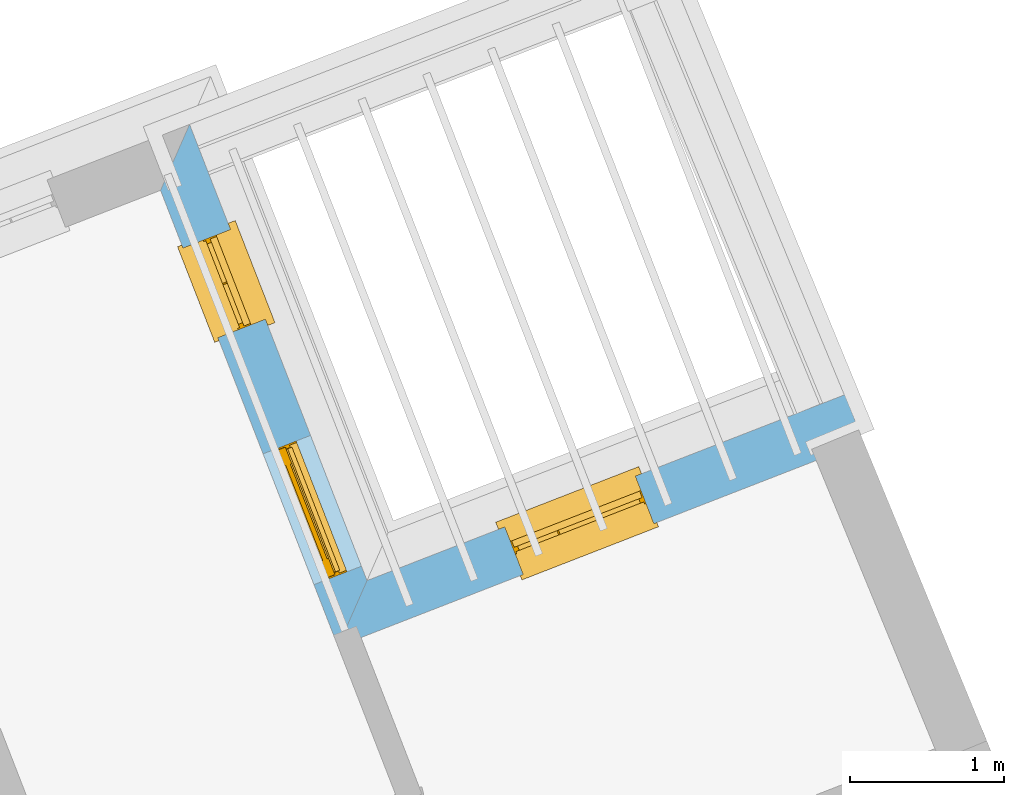
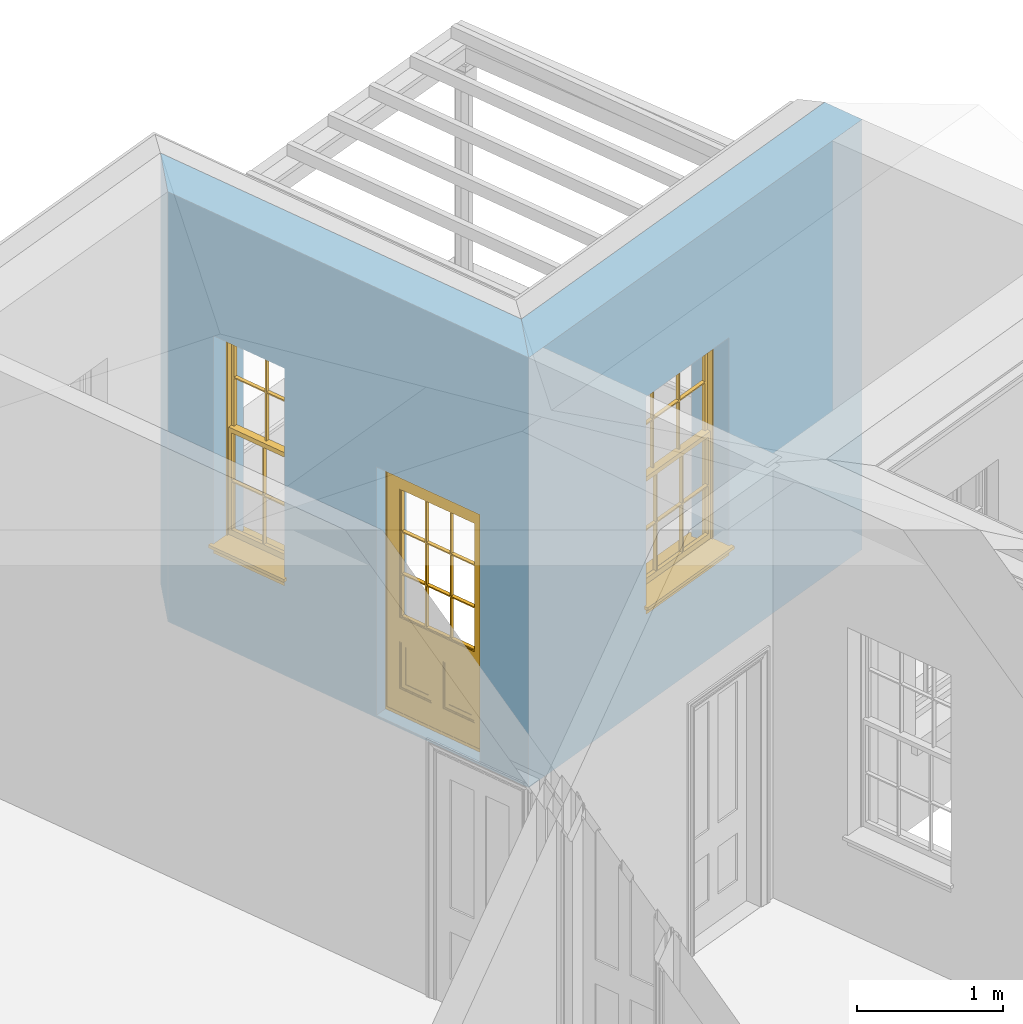
# One storey, part 9 of 11: 2 windows, 1 door, 3 openings, plus 2 elements that do not belong to this part.
"""IFC2X3 building model written with IfcOpenShell, lengths in metres."""

from ifc_helpers import new_model, si_unit, frame, origin, place, context, subcontext, project, spatial, polyline, outline, extrude, faceted_brep, material, layer, layer_set, layer_usage, element, fill, save


model = new_model("IFC2X3")

# Units and contexts
model_context = context("Model", 3, world=origin())
body_context = subcontext(model_context, "Body", "Model", "MODEL_VIEW")
ifc_project = project(units=[si_unit("PLANEANGLEUNIT", "RADIAN"), si_unit("MASSUNIT", "GRAM", prefix="KILO"), si_unit("FORCEUNIT", "NEWTON", prefix="KILO"), si_unit("LENGTHUNIT", "METRE")], contexts=[model_context])

# Site, building, storey
site_placement = place(None, origin())
site = spatial("IfcSite", under=ifc_project, at=site_placement, CompositionType="ELEMENT")
building_placement = place(None, origin())
building = spatial("IfcBuilding", under=site, at=building_placement, Name="Building plot-3", CompositionType="ELEMENT")
storey_placement = place(None, frame((0.0, 0.0, 5.45)))
storey = spatial("IfcBuildingStorey", under=building, at=storey_placement, Name="Floor 1", CompositionType="ELEMENT", Elevation=5.45)

# Wall, opening, window
ifc_material = material(Name="Masonry")
ifc_layer = layer(ifc_material, 0.33, ventilated=False)
ifc_layer_set = layer_set([ifc_layer], Name="My Wall")
ifc_layer_usage = layer_usage(ifc_layer_set, "AXIS2", "NEGATIVE", 0.08)
wall_1_placement = place(storey_placement, origin())
wall_1 = element("IfcWallStandardCase", 1, at=wall_1_placement, inside=storey, material=ifc_layer_usage, Name="exterior", context=body_context, shape_type="SweptSolid", body=[
    extrude(outline(polyline([(43.840490390188, 51.5411519545112), (43.7208486319546, 51.8487000803173), (40.6222717045672, 50.6432978667857), (40.4343653369945, 50.2161079827462), (43.840490390188, 51.5411519545112)])), origin(), (0.0, 0.0, 1.0), 3.6),
])
opening_1_placement = place(storey_placement, frame((0.0, 0.0, 0.75)))
opening_1 = element("IfcOpeningElement", 2, at=opening_1_placement, cuts=wall_1, Name="Opening", ObjectType="Opening", context=body_context, shape_type="SweptSolid", body=[
    extrude(outline(polyline([(42.3626127918676, 51.3203218839692), (41.514525535857, 50.990400671871), (41.6341672940904, 50.682852546065), (42.4822545501011, 51.0127737581632), (42.3626127918676, 51.3203218839692)])), origin(), (0.0, 0.0, 1.0), 1.82),
])
window_1_placement = place(storey_placement, frame((42.453250487499, 51.0873308795707, 0.75), z_axis=(0.0, 0.0, 1.0), x_axis=(-0.848087256010643, -0.329921212098199, 0.0)))
window_1 = element("IfcWindow", 3, at=window_1_placement, inside=storey, Name="toilet outside window", OverallHeight=1.82, OverallWidth=0.91, context=body_context, shape_type="Brep", held_by="IfcProductRepresentation", body=[
    faceted_brep([(0.033125, -0.105, 0.975209), (0.01, -0.105, 0.975209), (0.033125, -0.105, 1.376042), (0.876875, -0.105, 0.975209), (0.876875, -0.105, 1.376042), (0.9, -0.105, 0.975209), (0.876875, -0.105, 1.386042), (0.876875, -0.105, 1.786875), (0.9, -0.105, 1.81), (0.033125, -0.105, 1.786875), (0.033125, -0.105, 1.386042), (0.01, -0.105, 1.81), (0.876875, -0.135, 1.376042), (0.876875, -0.135, 0.975209), (0.9, -0.135, 0.937083), (0.033125, -0.135, 1.786875), (0.01, -0.135, 1.81), (0.033125, -0.135, 1.386042), (0.01, -0.135, 0.937083), (0.033125, -0.135, 0.975209), (0.033125, -0.135, 1.376042), (0.876875, -0.135, 1.786875), (0.876875, -0.135, 1.386042), (0.9, -0.135, 1.81), (0.033125, -0.105, 0.937083), (0.01, -0.105, 0.937083), (0.033125, -0.105, 0.53625), (0.876875, -0.105, 0.937083), (0.876875, -0.105, 0.53625), (0.9, -0.105, 0.937083), (0.876875, -0.105, 0.52625), (0.876875, -0.105, 0.125417), (0.9, -0.105, 0.077167), (0.033125, -0.105, 0.125417), (0.033125, -0.105, 0.52625), (0.01, -0.105, 0.077167), (-0.0425, -0.25, 0.01), (-0.0425, -0.3, 0.001667), (0.0, -0.25, 0.01), (0.9525, -0.25, 0.01), (0.91, -0.25, 0.01), (0.9525, -0.3, 0.001667), (-0.02, 0.08, 0.077167), (0.0, 0.08, 0.077167), (-0.02, 0.11, 0.077167), (0.0, -0.06, 0.077167), (0.01, -0.06, 0.077167), (0.91, -0.06, 0.077167), (0.91, 0.08, 0.077167), (0.9, -0.06, 0.077167), (0.93, 0.08, 0.077167), (0.93, 0.11, 0.077167), (0.01, -0.075, 0.975209), (0.9, -0.075, 0.975209), (0.876875, -0.075, 0.125417), (0.876875, -0.075, 0.52625), (0.9, -0.075, 0.077167), (0.876875, -0.075, 0.53625), (0.876875, -0.075, 0.937083), (0.033125, -0.075, 0.125417), (0.01, -0.075, 0.077167), (0.033125, -0.075, 0.52625), (0.033125, -0.075, 0.937083), (0.033125, -0.075, 0.53625), (-0.02, 0.08, 0.052167), (-0.02, 0.11, 0.052167), (0.93, 0.11, 0.052167), (0.93, 0.08, 0.052167), (0.91, 0.08, 0.052167), (0.0, 0.08, 0.052167), (0.91, -0.15, 0.026667), (0.0, -0.15, 0.026667), (-0.0425, -0.3, -0.123333), (0.9525, -0.3, -0.123333), (-0.0425, -0.25, -0.123333), (0.9525, -0.25, -0.123333), (0.01, -0.06, 1.81), (0.9, -0.06, 1.81), (0.0, -0.06, 1.82), (0.91, -0.06, 1.82), (0.01, -0.15, 0.077167), (0.9, -0.15, 0.077167), (0.592292, -0.105, 0.125417), (0.592292, -0.075, 0.125417), (0.317708, -0.075, 0.125417), (0.317708, -0.105, 0.125417), (0.592292, -0.105, 0.53625), (0.317708, -0.105, 0.53625), (0.317708, -0.105, 0.52625), (0.592292, -0.105, 0.52625), (0.592292, -0.075, 0.53625), (0.317708, -0.075, 0.53625), (0.592292, -0.135, 1.386042), (0.592292, -0.105, 1.386042), (0.317708, -0.105, 1.386042), (0.317708, -0.135, 1.386042), (0.317708, -0.135, 1.376042), (0.592292, -0.135, 1.376042), (0.317708, -0.105, 1.376042), (0.592292, -0.105, 1.376042), (0.602292, -0.135, 1.376042), (0.592292, -0.135, 0.975209), (0.602292, -0.135, 0.975209), (0.602292, -0.105, 0.975209), (0.592292, -0.105, 0.975209), (0.602292, -0.105, 1.376042), (0.602292, -0.075, 0.53625), (0.602292, -0.105, 0.53625), (0.317708, -0.075, 0.52625), (0.307708, -0.075, 0.125417), (0.307708, -0.075, 0.52625), (0.602292, -0.075, 0.52625), (0.602292, -0.075, 0.125417), (0.592292, -0.075, 0.52625), (0.307708, -0.075, 0.53625), (0.317708, -0.075, 0.937083), (0.307708, -0.075, 0.937083), (0.602292, -0.075, 0.937083), (0.592292, -0.075, 0.937083), (0.307708, -0.105, 0.52625), (0.307708, -0.105, 0.125417), (0.307708, -0.105, 0.53625), (0.307708, -0.105, 0.937083), (0.592292, -0.105, 0.937083), (0.317708, -0.105, 0.937083), (0.602292, -0.105, 0.937083), (0.602292, -0.105, 0.52625), (0.602292, -0.105, 0.125417), (0.307708, -0.135, 1.386042), (0.307708, -0.135, 1.376042), (0.307708, -0.135, 0.975209), (0.317708, -0.135, 0.975209), (0.317708, -0.135, 1.786875), (0.307708, -0.135, 1.786875), (0.602292, -0.135, 1.786875), (0.592292, -0.135, 1.786875), (0.602292, -0.135, 1.386042), (0.602292, -0.105, 1.386042), (0.307708, -0.105, 1.386042), (0.307708, -0.105, 1.786875), (0.317708, -0.105, 1.786875), (0.592292, -0.105, 1.786875), (0.602292, -0.105, 1.786875), (0.307708, -0.105, 1.376042), (0.317708, -0.105, 0.975209), (0.307708, -0.105, 0.975209), (0.91, -0.15, 1.82), (0.9, -0.15, 1.81), (0.01, -0.15, 1.81), (0.0, -0.15, 1.82), (0.91, -0.25, 0.0), (0.0, -0.25, 0.0), (0.91, 0.08, 0.0), (0.0, 0.08, 0.0)], [[[0, 1, 2]], [[3, 4, 5]], [[6, 7, 8]], [[9, 10, 11]], [[12, 13, 14]], [[15, 16, 17]], [[18, 19, 20]], [[21, 22, 23]], [[24, 25, 26]], [[27, 28, 29]], [[30, 31, 32]], [[33, 34, 35]], [[14, 27, 29]], [[25, 24, 18]], [[36, 37, 38]], [[39, 40, 41]], [[42, 43, 44]], [[45, 46, 43]], [[47, 48, 49]], [[50, 51, 48]], [[1, 0, 52]], [[5, 53, 3]], [[54, 55, 56]], [[57, 58, 53]], [[59, 60, 61]], [[62, 63, 52]], [[48, 43, 46, 49]], [[51, 44, 43, 48]], [[64, 42, 44, 65]], [[65, 44, 51, 66]], [[66, 51, 50, 67]], [[65, 66, 68, 69]], [[60, 56, 49, 46]], [[70, 71, 38, 40]], [[37, 41, 40, 38]], [[37, 72, 73, 41]], [[74, 75, 73, 72]], [[8, 11, 76, 77]], [[76, 78, 79, 77]], [[32, 35, 80, 81]], [[81, 80, 71, 70]], [[82, 83, 84, 85]], [[86, 87, 88, 89]], [[86, 90, 91, 87]], [[92, 93, 94, 95]], [[92, 95, 96, 97]], [[96, 98, 99, 97]], [[100, 97, 101, 102]], [[103, 104, 99, 105]], [[97, 99, 104, 101]], [[102, 103, 105, 100]], [[28, 57, 106, 107]], [[108, 84, 109, 110]], [[111, 112, 83, 113]], [[114, 110, 61, 63]], [[90, 113, 108, 91]], [[115, 91, 114, 116]], [[117, 106, 90, 118]], [[111, 106, 57, 55]], [[119, 110, 109, 120]], [[34, 61, 110, 119]], [[89, 113, 83, 82]], [[88, 108, 113, 89]], [[85, 84, 108, 88]], [[121, 114, 63, 26]], [[122, 116, 114, 121]], [[123, 118, 90, 86]], [[87, 91, 115, 124]], [[107, 106, 117, 125]], [[126, 111, 55, 30]], [[127, 112, 111, 126]], [[126, 30, 28, 107]], [[88, 119, 120, 85]], [[126, 89, 82, 127]], [[125, 123, 86, 107]], [[121, 26, 34, 119]], [[124, 122, 121, 87]], [[128, 17, 20, 129]], [[96, 129, 130, 131]], [[132, 133, 128, 95]], [[134, 135, 92, 136]], [[100, 12, 22, 136]], [[137, 6, 4, 105]], [[94, 138, 139, 140]], [[137, 93, 141, 142]], [[99, 98, 94, 93]], [[143, 2, 10, 138]], [[144, 145, 143, 98]], [[129, 143, 145, 130]], [[20, 2, 143, 129]], [[131, 144, 98, 96]], [[128, 138, 10, 17]], [[133, 139, 138, 128]], [[135, 141, 93, 92]], [[95, 94, 140, 132]], [[22, 6, 137, 136]], [[136, 137, 142, 134]], [[100, 105, 4, 12]], [[107, 86, 89, 126]], [[106, 111, 113, 90]], [[91, 108, 110, 114]], [[87, 121, 119, 88]], [[97, 100, 136, 92]], [[129, 96, 95, 128]], [[98, 143, 138, 94]], [[105, 99, 93, 137]], [[131, 101, 104, 144]], [[124, 115, 118, 123]], [[132, 140, 141, 135]], [[120, 109, 59, 33]], [[15, 9, 139, 133]], [[134, 142, 7, 21]], [[31, 54, 112, 127]], [[36, 74, 72, 37]], [[39, 41, 73, 75]], [[18, 14, 101, 131]], [[23, 16, 132, 135]], [[83, 56, 60, 84]], [[52, 53, 118, 115]], [[53, 52, 144, 104]], [[11, 8, 141, 140]], [[14, 18, 124, 123]], [[2, 1, 11, 10]], [[8, 5, 4, 6]], [[57, 53, 56, 55]], [[60, 52, 63, 61]], [[26, 25, 35, 34]], [[32, 29, 28, 30]], [[14, 23, 22, 12]], [[18, 20, 17, 16]], [[19, 0, 2, 20]], [[17, 10, 9, 15]], [[12, 4, 3, 13]], [[21, 7, 6, 22]], [[27, 58, 57, 28]], [[30, 55, 54, 31]], [[33, 59, 61, 34]], [[26, 63, 62, 24]], [[5, 8, 77, 53]], [[76, 11, 1, 52]], [[46, 45, 78, 76]], [[49, 77, 79, 47]], [[70, 146, 147, 81]], [[71, 80, 148, 149]], [[19, 130, 145, 0]], [[102, 13, 3, 103]], [[116, 122, 24, 62]], [[29, 32, 81, 14]], [[80, 35, 25, 18]], [[60, 46, 76, 52]], [[77, 49, 56, 53]], [[23, 14, 81, 147]], [[16, 148, 80, 18]], [[35, 85, 120]], [[120, 33, 35]], [[127, 82, 32]], [[32, 31, 127]], [[32, 82, 85, 35]], [[102, 101, 14]], [[14, 13, 102]], [[18, 131, 130]], [[130, 19, 18]], [[134, 21, 23]], [[23, 135, 134]], [[16, 15, 133]], [[133, 132, 16]], [[11, 140, 139]], [[139, 9, 11]], [[142, 141, 8]], [[8, 7, 142]], [[23, 147, 148, 16]], [[146, 149, 148, 147]], [[52, 115, 116]], [[116, 62, 52]], [[118, 53, 117]], [[58, 117, 53]], [[27, 125, 117, 58]], [[56, 83, 112]], [[112, 54, 56]], [[109, 84, 60]], [[60, 59, 109]], [[125, 27, 14]], [[14, 123, 125]], [[122, 124, 18]], [[18, 24, 122]], [[145, 144, 52]], [[52, 0, 145]], [[103, 3, 53]], [[53, 104, 103]], [[79, 78, 149, 146]], [[78, 45, 71, 149]], [[146, 70, 47, 79]], [[150, 75, 74, 151]], [[68, 66, 67]], [[48, 68, 67, 50]], [[69, 64, 65]], [[42, 64, 69, 43]], [[69, 68, 152, 153]], [[70, 68, 48, 47]], [[150, 152, 68, 70]], [[43, 69, 71, 45]], [[69, 153, 151, 71]], [[152, 150, 151, 153]], [[38, 151, 74, 36]], [[71, 151, 38]], [[39, 75, 150, 40]], [[40, 150, 70]]]),
])
fill(opening_1, window_1)

# Wall, openings, door, window
wall_2_placement = place(storey_placement, origin())
wall_2 = element("IfcWallStandardCase", 4, at=wall_2_placement, inside=storey, material=ifc_layer_usage, Name="exterior", context=body_context, shape_type="SweptSolid", body=[
    extrude(outline(polyline([(40.4343653369945, 50.2161079827462), (40.6222717045672, 50.6432978667857), (39.4717836497234, 53.6007138246754), (39.2838772821507, 53.1735239406359), (40.4343653369945, 50.2161079827462)])), origin(), (0.0, 0.0, 1.0), 3.6),
])
opening_2_placement = place(storey_placement, frame((0.0, 0.0, 0.0199999999999996)))
opening_2 = element("IfcOpeningElement", 5, at=opening_2_placement, cuts=wall_2, Name="Opening", ObjectType="Opening", context=body_context, shape_type="SweptSolid", body=[
    extrude(outline(polyline([(40.5860166263146, 50.7364942685451), (40.2560954142164, 51.5845815245558), (39.9485472884104, 51.4649397663223), (40.2784685005086, 50.6168525103117), (40.5860166263146, 50.7364942685451)])), origin(), (0.0, 0.0, 1.0), 2.08),
])
opening_3_placement = place(storey_placement, frame((0.0, 0.0, 0.75)))
opening_3 = element("IfcOpeningElement", 6, at=opening_3_placement, cuts=wall_2, Name="Opening", ObjectType="Opening", context=body_context, shape_type="SweptSolid", body=[
    extrude(outline(polyline([(39.9633404786049, 52.3371300753063), (39.7367462395265, 52.9196075863026), (39.4291981137204, 52.7999658280692), (39.6557923527988, 52.2174883170729), (39.9633404786049, 52.3371300753063)])), origin(), (0.0, 0.0, 1.0), 1.82),
])
door_placement = place(storey_placement, frame((40.3530256219161, 50.6458565729137, 0.0199999999999996), z_axis=(0.0, 0.0, 1.0), x_axis=(-0.329921212098192, 0.848087256010643, 0.0)))
door = element("IfcDoor", 7, at=door_placement, inside=storey, Name="circulation outside door", OverallHeight=2.08, OverallWidth=0.91, context=body_context, shape_type="Brep", held_by="IfcProductRepresentation", body=[
    faceted_brep([(0.545, -0.055, 0.265), (0.745, -0.055, 0.265), (0.745, -0.05, 0.265), (0.545, -0.05, 0.265), (0.745, -0.05, 0.58), (0.545, -0.05, 0.58), (0.545, -0.055, 0.58), (0.515, -0.06, 0.235), (0.775, -0.06, 0.235), (0.745, -0.055, 0.58), (0.515, -0.06, 0.61), (0.515, -0.065, 0.235), (0.775, -0.065, 0.235), (0.775, -0.06, 0.61), (0.515, -0.065, 0.61), (0.785, -0.065, 0.225), (0.505, -0.065, 0.225), (0.775, -0.065, 0.61), (0.505, -0.065, 0.62), (0.785, -0.065, 0.62), (0.505, -0.07, 0.225), (0.785, -0.07, 0.225), (0.505, -0.07, 0.62), (0.785, -0.07, 0.62), (0.883, -0.07, 0.075), (0.898, -0.07, 0.075), (0.405, -0.07, 0.62), (0.405, -0.07, 0.225), (0.027, -0.07, 0.075), (0.785, -0.07, 0.82), (0.125, -0.07, 0.82), (0.405, -0.065, 0.62), (0.405, -0.065, 0.225), (0.898, -0.07, 2.068), (0.027, -0.08, 0.075), (0.883, -0.08, 0.075), (0.125, -0.07, 0.225), (0.012, -0.07, 0.075), (0.785, -0.06, 0.82), (0.125, -0.06, 0.82), (0.125, -0.07, 0.62), (0.125, -0.065, 0.62), (0.395, -0.065, 0.61), (0.395, -0.065, 0.235), (0.125, -0.065, 0.225), (0.785, -0.07, 1.895), (0.027, -0.11, 0.045), (0.883, -0.11, 0.045), (0.558333, -0.06, 0.83), (0.351667, -0.06, 0.83), (0.125, -0.07, 1.895), (0.125, -0.06, 1.895), (0.785, -0.06, 1.895), (0.012, -0.07, 2.068), (0.135, -0.065, 0.61), (0.395, -0.06, 0.61), (0.395, -0.06, 0.235), (0.135, -0.065, 0.235), (0.027, -0.11, 0.027), (0.883, -0.11, 0.027), (0.568333, -0.06, 0.83), (0.558333, -0.03, 0.83), (0.351667, -0.03, 0.83), (0.341667, -0.06, 0.83), (0.135, -0.06, 1.185), (0.135, -0.06, 1.53), (0.775, -0.06, 1.53), (0.775, -0.06, 1.185), (0.135, -0.06, 0.61), (0.365, -0.055, 0.58), (0.365, -0.055, 0.265), (0.135, -0.06, 0.235), (0.568333, -0.06, 1.175), (0.558333, -0.06, 1.175), (0.775, -0.06, 0.83), (0.558333, -0.03, 1.175), (0.785, -0.03, 0.82), (0.125, -0.03, 0.82), (0.351667, -0.03, 1.175), (0.351667, -0.06, 1.175), (0.341667, -0.06, 1.175), (0.135, -0.06, 0.83), (0.135, -0.06, 1.175), (0.135, -0.03, 1.185), (0.135, -0.03, 1.53), (0.135, -0.06, 1.54), (0.351667, -0.06, 1.885), (0.558333, -0.06, 1.885), (0.775, -0.03, 1.53), (0.775, -0.03, 1.185), (0.775, -0.06, 1.175), (0.775, -0.06, 1.54), (0.165, -0.055, 0.58), (0.365, -0.05, 0.58), (0.365, -0.05, 0.265), (0.165, -0.055, 0.265), (0.568333, -0.03, 0.83), (0.568333, -0.03, 1.175), (0.568333, -0.06, 1.185), (0.558333, -0.06, 1.185), (0.775, -0.03, 0.83), (0.785, -0.02, 0.82), (0.125, -0.02, 0.82), (0.341667, -0.03, 0.83), (0.341667, -0.03, 1.175), (0.351667, -0.06, 1.185), (0.341667, -0.06, 1.185), (0.135, -0.03, 0.83), (0.341667, -0.03, 1.185), (0.125, -0.03, 1.895), (0.341667, -0.03, 1.53), (0.341667, -0.06, 1.53), (0.135, -0.06, 1.885), (0.341667, -0.06, 1.54), (0.341667, -0.06, 1.885), (0.558333, -0.03, 1.885), (0.351667, -0.03, 1.885), (0.568333, -0.06, 1.885), (0.785, -0.03, 1.895), (0.568333, -0.03, 1.185), (0.568333, -0.06, 1.53), (0.568333, -0.03, 1.53), (0.568333, -0.06, 1.54), (0.775, -0.06, 1.885), (0.165, -0.05, 0.58), (0.165, -0.05, 0.265), (0.775, -0.03, 1.175), (0.558333, -0.06, 1.53), (0.351667, -0.03, 1.185), (0.558333, -0.03, 1.185), (0.505, -0.02, 0.62), (0.405, -0.02, 0.62), (0.125, -0.02, 1.895), (0.785, -0.02, 1.895), (0.351667, -0.06, 1.53), (0.135, -0.03, 1.175), (0.135, -0.03, 1.54), (0.341667, -0.03, 1.54), (0.135, -0.03, 1.885), (0.351667, -0.06, 1.54), (0.558333, -0.03, 1.54), (0.558333, -0.06, 1.54), (0.351667, -0.03, 1.54), (0.775, -0.03, 1.54), (0.568333, -0.03, 1.54), (0.775, -0.03, 1.885), (0.558333, -0.03, 1.53), (0.405, -0.02, 0.225), (0.505, -0.02, 0.225), (0.125, -0.02, 0.62), (0.785, -0.02, 0.62), (0.012, -0.02, 2.068), (0.898, -0.02, 2.068), (0.351667, -0.03, 1.53), (0.341667, -0.03, 1.885), (0.568333, -0.03, 1.885), (0.405, -0.025, 0.225), (0.405, -0.025, 0.62), (0.505, -0.025, 0.62), (0.505, -0.025, 0.225), (0.898, -0.02, 0.027), (0.012, -0.02, 0.027), (0.125, -0.025, 0.62), (0.785, -0.025, 0.62), (0.395, -0.025, 0.235), (0.395, -0.025, 0.61), (0.125, -0.02, 0.225), (0.125, -0.025, 0.225), (0.515, -0.025, 0.61), (0.515, -0.025, 0.235), (0.785, -0.02, 0.225), (0.785, -0.025, 0.225), (0.135, -0.025, 0.61), (0.775, -0.025, 0.61), (0.135, -0.025, 0.235), (0.395, -0.03, 0.235), (0.395, -0.03, 0.61), (0.515, -0.03, 0.61), (0.515, -0.03, 0.235), (0.775, -0.025, 0.235), (0.135, -0.03, 0.61), (0.775, -0.03, 0.61), (0.135, -0.03, 0.235), (0.365, -0.035, 0.265), (0.365, -0.035, 0.58), (0.545, -0.035, 0.58), (0.545, -0.035, 0.265), (0.775, -0.03, 0.235), (0.165, -0.035, 0.58), (0.745, -0.035, 0.58), (0.165, -0.035, 0.265), (0.365, -0.04, 0.58), (0.365, -0.04, 0.265), (0.545, -0.04, 0.58), (0.545, -0.04, 0.265), (0.745, -0.035, 0.265), (0.165, -0.04, 0.58), (0.745, -0.04, 0.58), (0.165, -0.04, 0.265), (0.745, -0.04, 0.265), (0.885, -0.072, 0.025), (0.025, -0.072, 0.025), (0.025, -0.1, 0.025), (0.885, -0.1, 0.025), (0.9, -0.02, 0.025), (0.01, -0.02, 0.025), (0.9, -0.072, 0.025), (0.91, -0.02, 0.0), (0.0, -0.02, 0.0), (0.01, -0.072, 0.025), (0.9, -0.072, 2.07), (0.9, -0.02, 2.07), (0.885, -0.072, 2.055), (0.91, -0.02, 2.08), (0.01, -0.02, 2.07), (0.0, -0.02, 2.08), (0.01, -0.072, 2.07), (0.025, -0.072, 2.055), (0.0, -0.15, 2.08), (0.91, -0.15, 2.08), (0.01, -0.15, 2.07), (0.9, -0.15, 2.07), (0.01, -0.1, 2.07), (0.9, -0.1, 2.07), (0.0, -0.15, 0.0), (0.91, -0.15, 0.0), (0.01, -0.15, 0.025), (0.9, -0.15, 0.025), (0.01, -0.1, 0.025), (0.025, -0.1, 2.055), (0.9, -0.1, 0.025), (0.885, -0.1, 2.055), (0.898, -0.07, 0.027), (0.012, -0.07, 0.027), (0.883, -0.07, 0.027), (0.027, -0.07, 0.027)], [[[0, 1, 2, 3]], [[2, 4, 5, 3]], [[0, 3, 5, 6]], [[1, 0, 7, 8]], [[9, 4, 2, 1]], [[9, 6, 5, 4]], [[0, 6, 10, 7]], [[8, 7, 11, 12]], [[8, 13, 9, 1]], [[13, 10, 6, 9]], [[7, 10, 14, 11]], [[15, 12, 11, 16]], [[12, 17, 13, 8]], [[17, 14, 10, 13]], [[18, 16, 11, 14]], [[15, 19, 17, 12]], [[15, 16, 20, 21]], [[14, 17, 19, 18]], [[16, 18, 22, 20]], [[21, 23, 19, 15]], [[24, 25, 21, 20]], [[23, 22, 18, 19]], [[20, 22, 26, 27]], [[23, 21, 25]], [[28, 24, 20, 27]], [[22, 23, 29]], [[29, 30, 26, 22]], [[27, 26, 31, 32]], [[23, 25, 33, 29]], [[34, 35, 24, 28]], [[28, 27, 36, 37]], [[38, 39, 30, 29]], [[26, 30, 40]], [[26, 40, 41, 31]], [[42, 43, 32, 31]], [[32, 44, 36, 27]], [[33, 45, 29]], [[46, 47, 35, 34]], [[36, 40, 37]], [[39, 38, 48, 49]], [[50, 30, 39, 51]], [[29, 45, 52, 38]], [[53, 37, 40, 30]], [[44, 41, 40, 36]], [[31, 41, 54, 42]], [[43, 42, 55, 56]], [[57, 44, 32, 43]], [[50, 45, 33, 53]], [[47, 46, 58, 59]], [[60, 48, 38]], [[49, 48, 61, 62]], [[49, 63, 39]], [[50, 53, 30]], [[51, 39, 64, 65]], [[45, 50, 51, 52]], [[66, 67, 38, 52]], [[57, 54, 41, 44]], [[42, 54, 68, 55]], [[56, 55, 69, 70]], [[56, 71, 57, 43]], [[60, 72, 73, 48]], [[60, 38, 74]], [[48, 73, 75, 61]], [[76, 77, 62, 61]], [[62, 78, 79, 49]], [[49, 79, 80, 63]], [[63, 81, 39]], [[82, 64, 39]], [[65, 64, 83, 84]], [[85, 51, 65]], [[52, 51, 86, 87]], [[88, 89, 67, 66]], [[90, 38, 67]], [[91, 66, 52]], [[71, 68, 54, 57]], [[55, 68, 92, 69]], [[69, 93, 94, 70]], [[70, 95, 71, 56]], [[96, 97, 72, 60]], [[73, 72, 98, 99]], [[74, 38, 90]], [[100, 96, 60, 74]], [[75, 73, 79, 78]], [[61, 75, 97, 96]], [[101, 102, 77, 76]], [[77, 103, 62]], [[96, 76, 61]], [[103, 104, 78, 62]], [[80, 79, 105, 106]], [[63, 80, 104, 103]], [[81, 63, 103, 107]], [[81, 82, 39]], [[106, 64, 82, 80]], [[106, 108, 83, 64]], [[84, 83, 77, 109]], [[110, 111, 65, 84]], [[112, 51, 85]], [[113, 85, 65, 111]], [[114, 86, 51]], [[115, 87, 86, 116]], [[117, 52, 87]], [[118, 76, 89, 88]], [[119, 98, 67, 89]], [[120, 121, 88, 66]], [[67, 98, 72, 90]], [[91, 122, 120, 66]], [[91, 52, 123]], [[95, 92, 68, 71]], [[69, 92, 124, 93]], [[94, 93, 124, 125]], [[94, 125, 95, 70]], [[72, 97, 126, 90]], [[127, 99, 98, 120]], [[99, 105, 79, 73]], [[74, 90, 126, 100]], [[96, 100, 76]], [[128, 129, 75, 78]], [[97, 75, 129, 119]], [[130, 131, 102, 101]], [[109, 77, 102, 132]], [[133, 101, 76, 118]], [[77, 107, 103]], [[78, 104, 108, 128]], [[111, 106, 105, 134]], [[104, 80, 82, 135]], [[107, 135, 82, 81]], [[110, 108, 106, 111]], [[104, 135, 83, 108]], [[83, 135, 77]], [[136, 84, 109]], [[110, 84, 136, 137]], [[114, 51, 112]], [[85, 136, 138, 112]], [[113, 137, 136, 85]], [[111, 134, 139, 113]], [[86, 114, 113, 139]], [[140, 141, 87, 115]], [[139, 142, 116, 86]], [[109, 118, 115, 116]], [[117, 123, 52]], [[117, 87, 141, 122]], [[126, 89, 76]], [[143, 118, 88]], [[120, 98, 119, 121]], [[119, 89, 126, 97]], [[144, 143, 88, 121]], [[144, 122, 91, 143]], [[127, 120, 122, 141]], [[143, 91, 123, 145]], [[124, 92, 95, 125]], [[146, 129, 99, 127]], [[99, 129, 128, 105]], [[100, 126, 76]], [[121, 119, 129, 146]], [[147, 131, 130, 148]], [[131, 149, 102]], [[130, 101, 150]], [[102, 151, 132]], [[118, 109, 132, 133]], [[101, 133, 152]], [[107, 77, 135]], [[153, 128, 108, 110]], [[134, 105, 128, 153]], [[109, 138, 136]], [[153, 110, 137, 142]], [[154, 114, 112, 138]], [[137, 113, 114, 154]], [[141, 139, 134, 127]], [[141, 140, 142, 139]], [[144, 140, 115, 155]], [[142, 137, 154, 116]], [[155, 115, 118]], [[116, 154, 109]], [[117, 155, 145, 123]], [[122, 144, 155, 117]], [[143, 145, 118]], [[121, 146, 140, 144]], [[146, 127, 134, 153]], [[156, 157, 131, 147]], [[148, 130, 158, 159]], [[148, 160, 161, 147]], [[157, 162, 149, 131]], [[161, 151, 102, 149]], [[101, 152, 160, 150]], [[163, 158, 130, 150]], [[151, 152, 133, 132]], [[154, 138, 109]], [[142, 140, 146, 153]], [[145, 155, 118]], [[157, 156, 164, 165]], [[147, 166, 167, 156]], [[168, 169, 159, 158]], [[170, 148, 159, 171]], [[148, 170, 160]], [[166, 147, 161]], [[172, 162, 157, 165]], [[166, 149, 162, 167]], [[166, 161, 149]], [[150, 160, 170]], [[163, 173, 168, 158]], [[171, 163, 150, 170]], [[174, 164, 156, 167]], [[175, 176, 165, 164]], [[169, 168, 177, 178]], [[171, 159, 169, 179]], [[167, 162, 172, 174]], [[176, 180, 172, 165]], [[179, 173, 163, 171]], [[181, 177, 168, 173]], [[164, 174, 182, 175]], [[183, 184, 176, 175]], [[178, 177, 185, 186]], [[179, 169, 178, 187]], [[174, 172, 180, 182]], [[184, 188, 180, 176]], [[187, 181, 173, 179]], [[189, 185, 177, 181]], [[175, 182, 190, 183]], [[191, 184, 183, 192]], [[185, 193, 194, 186]], [[187, 178, 186, 195]], [[182, 180, 188, 190]], [[191, 196, 188, 184]], [[195, 189, 181, 187]], [[197, 193, 185, 189]], [[183, 190, 198, 192]], [[198, 196, 191, 192]], [[194, 193, 197, 199]], [[195, 186, 194, 199]], [[188, 196, 198, 190]], [[197, 189, 195, 199]], [[200, 201, 202, 203]], [[201, 200, 204, 205]], [[206, 204, 200]], [[204, 207, 208, 205]], [[209, 201, 205]], [[210, 211, 204, 206]], [[206, 200, 212, 210]], [[211, 213, 207, 204]], [[214, 205, 208, 215]], [[216, 217, 201, 209]], [[205, 214, 216, 209]], [[216, 214, 211, 210]], [[210, 212, 217, 216]], [[214, 215, 213, 211]], [[218, 219, 213, 215]], [[219, 218, 220, 221]], [[221, 220, 222, 223]], [[215, 208, 224, 218]], [[225, 224, 208, 207]], [[224, 226, 220, 218]], [[224, 225, 227, 226]], [[219, 225, 207, 213]], [[228, 222, 220, 226]], [[219, 221, 227, 225]], [[226, 227, 203, 202]], [[202, 229, 222, 228]], [[228, 226, 202]], [[227, 221, 223, 230]], [[230, 203, 227]], [[217, 229, 202, 201]], [[231, 223, 222, 229]], [[230, 223, 231, 203]], [[231, 229, 217, 212]], [[212, 200, 203, 231]], [[33, 152, 151, 53]], [[25, 160, 152, 33]], [[161, 37, 53, 151]], [[232, 160, 25]], [[161, 233, 37]], [[160, 232, 234]], [[24, 234, 232, 25]], [[233, 161, 235]], [[37, 233, 235, 28]], [[161, 160, 234, 235]], [[35, 47, 234, 24]], [[28, 235, 46, 34]], [[58, 235, 234, 59]], [[59, 234, 47]], [[58, 46, 235]]]),
])
fill(opening_2, door)
window_2_placement = place(storey_placement, frame((39.7303494742064, 52.2464923796749, 0.75), z_axis=(0.0, 0.0, 1.0), x_axis=(-0.22659423907843, 0.58247751099632, 0.0)))
window_2 = element("IfcWindow", 8, at=window_2_placement, inside=storey, Name="circulation outside window", OverallHeight=1.82, OverallWidth=0.625, context=body_context, shape_type="Brep", held_by="IfcProductRepresentation", body=[
    faceted_brep([(0.033125, -0.105, 0.975209), (0.01, -0.105, 0.975209), (0.033125, -0.105, 1.376042), (0.591875, -0.105, 0.975209), (0.591875, -0.105, 1.376042), (0.615, -0.105, 0.975209), (0.591875, -0.105, 1.386042), (0.591875, -0.105, 1.786875), (0.615, -0.105, 1.81), (0.033125, -0.105, 1.786875), (0.033125, -0.105, 1.386042), (0.01, -0.105, 1.81), (0.591875, -0.135, 1.376042), (0.591875, -0.135, 0.975209), (0.615, -0.135, 0.937083), (0.033125, -0.135, 1.786875), (0.01, -0.135, 1.81), (0.033125, -0.135, 1.386042), (0.01, -0.135, 0.937083), (0.033125, -0.135, 0.975209), (0.033125, -0.135, 1.376042), (0.591875, -0.135, 1.786875), (0.591875, -0.135, 1.386042), (0.615, -0.135, 1.81), (0.033125, -0.105, 0.937083), (0.01, -0.105, 0.937083), (0.033125, -0.105, 0.53625), (0.591875, -0.105, 0.937083), (0.591875, -0.105, 0.53625), (0.615, -0.105, 0.937083), (0.591875, -0.105, 0.52625), (0.591875, -0.105, 0.125417), (0.615, -0.105, 0.077167), (0.033125, -0.105, 0.125417), (0.033125, -0.105, 0.52625), (0.01, -0.105, 0.077167), (-0.0425, -0.25, 0.01), (-0.0425, -0.3, 0.001667), (0.0, -0.25, 0.01), (0.6675, -0.25, 0.01), (0.625, -0.25, 0.01), (0.6675, -0.3, 0.001667), (-0.02, 0.08, 0.077167), (0.0, 0.08, 0.077167), (-0.02, 0.11, 0.077167), (0.0, -0.06, 0.077167), (0.01, -0.06, 0.077167), (0.625, -0.06, 0.077167), (0.625, 0.08, 0.077167), (0.615, -0.06, 0.077167), (0.645, 0.08, 0.077167), (0.645, 0.11, 0.077167), (0.01, -0.075, 0.975209), (0.615, -0.075, 0.975209), (0.591875, -0.075, 0.125417), (0.591875, -0.075, 0.52625), (0.615, -0.075, 0.077167), (0.591875, -0.075, 0.53625), (0.591875, -0.075, 0.937083), (0.033125, -0.075, 0.125417), (0.01, -0.075, 0.077167), (0.033125, -0.075, 0.52625), (0.033125, -0.075, 0.937083), (0.033125, -0.075, 0.53625), (-0.02, 0.08, 0.052167), (-0.02, 0.11, 0.052167), (0.645, 0.11, 0.052167), (0.645, 0.08, 0.052167), (0.625, 0.08, 0.052167), (0.0, 0.08, 0.052167), (0.625, -0.15, 0.026667), (0.0, -0.15, 0.026667), (-0.0425, -0.3, -0.123333), (0.6675, -0.3, -0.123333), (-0.0425, -0.25, -0.123333), (0.6675, -0.25, -0.123333), (0.01, -0.06, 1.81), (0.615, -0.06, 1.81), (0.0, -0.06, 1.82), (0.625, -0.06, 1.82), (0.01, -0.15, 0.077167), (0.615, -0.15, 0.077167), (0.3175, -0.075, 0.53625), (0.3175, -0.105, 0.53625), (0.3175, -0.075, 0.52625), (0.3175, -0.075, 0.125417), (0.3075, -0.075, 0.125417), (0.3075, -0.075, 0.52625), (0.3075, -0.075, 0.53625), (0.3175, -0.075, 0.937083), (0.3075, -0.075, 0.937083), (0.3075, -0.105, 0.52625), (0.3075, -0.105, 0.125417), (0.3175, -0.105, 0.125417), (0.3175, -0.105, 0.52625), (0.3075, -0.105, 0.53625), (0.3075, -0.105, 0.937083), (0.3175, -0.105, 0.937083), (0.3075, -0.135, 1.386042), (0.3075, -0.135, 1.376042), (0.3175, -0.135, 1.376042), (0.3075, -0.135, 0.975209), (0.3175, -0.135, 0.975209), (0.3175, -0.135, 1.786875), (0.3075, -0.135, 1.786875), (0.3175, -0.135, 1.386042), (0.3175, -0.105, 1.386042), (0.3175, -0.105, 1.376042), (0.3075, -0.105, 1.386042), (0.3075, -0.105, 1.786875), (0.3175, -0.105, 1.786875), (0.3075, -0.105, 1.376042), (0.3175, -0.105, 0.975209), (0.3075, -0.105, 0.975209), (0.625, -0.15, 1.82), (0.615, -0.15, 1.81), (0.01, -0.15, 1.81), (0.0, -0.15, 1.82), (0.625, -0.25, 0.0), (0.0, -0.25, 0.0), (0.625, 0.08, 0.0), (0.0, 0.08, 0.0)], [[[0, 1, 2]], [[3, 4, 5]], [[6, 7, 8]], [[9, 10, 11]], [[12, 13, 14]], [[15, 16, 17]], [[18, 19, 20]], [[21, 22, 23]], [[24, 25, 26]], [[27, 28, 29]], [[30, 31, 32]], [[33, 34, 35]], [[14, 27, 29]], [[25, 24, 18]], [[36, 37, 38]], [[39, 40, 41]], [[42, 43, 44]], [[45, 46, 43]], [[47, 48, 49]], [[50, 51, 48]], [[1, 0, 52]], [[5, 53, 3]], [[54, 55, 56]], [[57, 58, 53]], [[59, 60, 61]], [[62, 63, 52]], [[48, 43, 46, 49]], [[51, 44, 43, 48]], [[64, 42, 44, 65]], [[65, 44, 51, 66]], [[66, 51, 50, 67]], [[65, 66, 68, 69]], [[60, 56, 49, 46]], [[70, 71, 38, 40]], [[37, 41, 40, 38]], [[37, 72, 73, 41]], [[74, 75, 73, 72]], [[8, 11, 76, 77]], [[76, 78, 79, 77]], [[32, 35, 80, 81]], [[81, 80, 71, 70]], [[28, 57, 82, 83]], [[84, 85, 86, 87]], [[88, 87, 61, 63]], [[89, 82, 88, 90]], [[84, 82, 57, 55]], [[91, 87, 86, 92]], [[34, 61, 87, 91]], [[93, 85, 84, 94]], [[95, 88, 63, 26]], [[96, 90, 88, 95]], [[83, 82, 89, 97]], [[94, 84, 55, 30]], [[94, 30, 28, 83]], [[94, 91, 92, 93]], [[95, 26, 34, 91]], [[97, 96, 95, 83]], [[98, 17, 20, 99]], [[100, 99, 101, 102]], [[103, 104, 98, 105]], [[100, 12, 22, 105]], [[106, 6, 4, 107]], [[106, 108, 109, 110]], [[111, 2, 10, 108]], [[112, 113, 111, 107]], [[99, 111, 113, 101]], [[20, 2, 111, 99]], [[102, 112, 107, 100]], [[98, 108, 10, 17]], [[104, 109, 108, 98]], [[105, 106, 110, 103]], [[22, 6, 106, 105]], [[100, 107, 4, 12]], [[82, 84, 87, 88]], [[83, 95, 91, 94]], [[99, 100, 105, 98]], [[107, 111, 108, 106]], [[92, 86, 59, 33]], [[15, 9, 109, 104]], [[103, 110, 7, 21]], [[31, 54, 85, 93]], [[36, 74, 72, 37]], [[39, 41, 73, 75]], [[18, 14, 102, 101]], [[23, 16, 104, 103]], [[85, 56, 60, 86]], [[52, 53, 89, 90]], [[53, 52, 113, 112]], [[11, 8, 110, 109]], [[14, 18, 96, 97]], [[2, 1, 11, 10]], [[8, 5, 4, 6]], [[57, 53, 56, 55]], [[60, 52, 63, 61]], [[26, 25, 35, 34]], [[32, 29, 28, 30]], [[14, 23, 22, 12]], [[18, 20, 17, 16]], [[19, 0, 2, 20]], [[17, 10, 9, 15]], [[12, 4, 3, 13]], [[21, 7, 6, 22]], [[27, 58, 57, 28]], [[30, 55, 54, 31]], [[33, 59, 61, 34]], [[26, 63, 62, 24]], [[5, 8, 77, 53]], [[76, 11, 1, 52]], [[46, 45, 78, 76]], [[49, 77, 79, 47]], [[70, 114, 115, 81]], [[71, 80, 116, 117]], [[19, 101, 113, 0]], [[102, 13, 3, 112]], [[90, 96, 24, 62]], [[29, 32, 81, 14]], [[80, 35, 25, 18]], [[60, 46, 76, 52]], [[77, 49, 56, 53]], [[23, 14, 81, 115]], [[16, 116, 80, 18]], [[92, 33, 35]], [[32, 31, 93]], [[32, 93, 92, 35]], [[14, 13, 102]], [[101, 19, 18]], [[103, 21, 23]], [[16, 15, 104]], [[109, 9, 11]], [[8, 7, 110]], [[23, 115, 116, 16]], [[114, 117, 116, 115]], [[90, 62, 52]], [[58, 89, 53]], [[27, 97, 89, 58]], [[85, 54, 56]], [[60, 59, 86]], [[97, 27, 14]], [[18, 24, 96]], [[52, 0, 113]], [[112, 3, 53]], [[79, 78, 117, 114]], [[78, 45, 71, 117]], [[114, 70, 47, 79]], [[118, 75, 74, 119]], [[68, 66, 67]], [[48, 68, 67, 50]], [[69, 64, 65]], [[42, 64, 69, 43]], [[69, 68, 120, 121]], [[70, 68, 48, 47]], [[118, 120, 68, 70]], [[43, 69, 71, 45]], [[69, 121, 119, 71]], [[120, 118, 119, 121]], [[38, 119, 74, 36]], [[71, 119, 38]], [[39, 75, 118, 40]], [[40, 118, 70]]]),
])
fill(opening_3, window_2)

save(model, "model.ifc")
